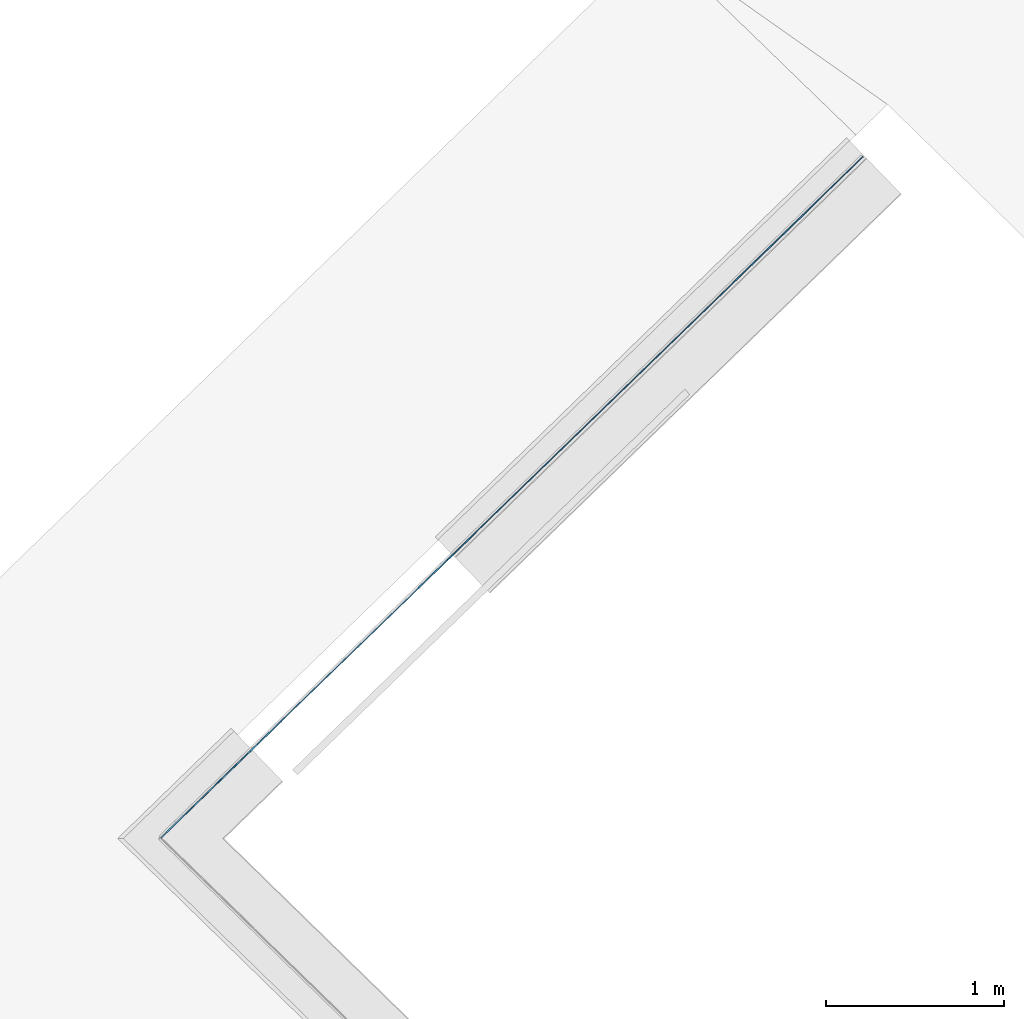
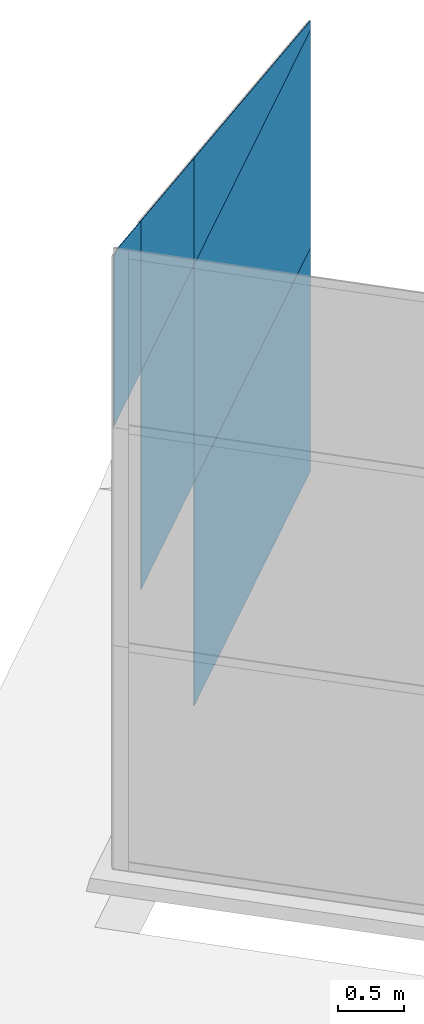
# One storey, part 10 of 13: 6 plates, 1 element without a shape of its own.
"""IFC4 building model written with IfcOpenShell, lengths in metres."""

from ifc_helpers import new_model, entity, si_unit, converted_unit, direction, frame, origin, place, context, subcontext, project, spatial, indexed_curve, outline, extrude, source, transform, mapped, material, type_object, type_shapes, element, aggregate, save


model = new_model("IFC4")

# Units and contexts
model_context = context("Model", 3, precision=1e-05, world=origin(), true_north=direction((6.123233995736766e-17, 1.0)))
body_context = subcontext(model_context, "Body", "Model", "MODEL_VIEW")
ifc_project = project(units=[si_unit("LENGTHUNIT", "METRE"), si_unit("AREAUNIT", "SQUARE_METRE"), si_unit("VOLUMEUNIT", "CUBIC_METRE"), converted_unit("PLANEANGLEUNIT", "DEGREE", entity("IfcPlaneAngleMeasure", 0.017453292519943278), si_unit("PLANEANGLEUNIT", "RADIAN"), dimensions=[0, 0, 0, 0, 0, 0, 0])], contexts=[model_context])

# Site, building, storey
site_placement = place(None, frame((0.0, 0.0, 0.0), z_axis=(0.0, 0.0, 1.0), x_axis=(0.7160934825303189, -0.6980043870045516, 0.0)))
site = spatial("IfcSite", under=ifc_project, at=site_placement, CompositionType="ELEMENT")
building_placement = place(site_placement, origin())
building = spatial("IfcBuilding", under=site, at=building_placement, CompositionType="ELEMENT")
storey_placement = place(building_placement, frame((0.0, 0.0, -7.0)))
storey = spatial("IfcBuildingStorey", under=building, at=storey_placement, Name="-7.00 m", CompositionType="ELEMENT", Elevation=-7.000000000000001)

# Curtain wall, plates
curtain_wall_type = type_object("IfcCurtainWallType", Name="Facciata continua:Vetrata_1", PredefinedType="NOTDEFINED")
curtain_wall_placement = place(storey_placement, frame((0.0, 0.0, 7.0)))
curtain_wall = element("IfcCurtainWall", 1, at=curtain_wall_placement, inside=storey, type_object=curtain_wall_type, Name="Facciata continua:Vetrata_1", ObjectType="Facciata continua:Vetrata_1", PredefinedType="NOTDEFINED")
ifc_material = material(Name="Default - Vetro", Category="Vetro")
plate_type_1 = type_object("IfcPlateType", Name="Pannello sistema:Vetrato_fine", PredefinedType="CURTAIN_PANEL", material=ifc_material)
shared_shape_1 = source(origin(), body_context, "Body", "SweptSolid", [
    extrude(outline(indexed_curve([(-0.0025, -1.624879808806576), (0.0025, -1.624879808806576), (0.0025, 1.624879808806576), (-0.0025, 1.624879808806576), (-0.0025, -1.624879808806576)], self_intersect=False)), frame((0.0, 0.0, 0.0), z_axis=(0.0, 0.0, 1.0), x_axis=(0.0, 1.0, 0.0)), (0.0, 0.0, 1.0), 2.079999999999999),
])
type_shapes(plate_type_1, [shared_shape_1])
plate_1_placement = place(curtain_wall_placement, frame((-27.70563502134957, -3.1169319345284583, -6.9399999999999995), z_axis=(0.0, 0.0, 1.0), x_axis=(-0.027980069795956325, -0.9996084812036228, 0.0)))
plate_1 = element("IfcPlate", 2, at=plate_1_placement, type_object=plate_type_1, material=ifc_material, Name="Pannello sistema:Vetrato_fine", ObjectType="Pannello sistema:Vetrato_fine", PredefinedType="CURTAIN_PANEL", context=body_context, shape_type="MappedRepresentation", body=[
    mapped(shared_shape_1, transform((0.0, 0.0, 0.0), scale=1.0)),
])
plate_type_2 = type_object("IfcPlateType", Name="Pannello sistema:Vetrato_fine", PredefinedType="CURTAIN_PANEL", material=ifc_material)
shared_shape_2 = source(origin(), body_context, "Body", "SweptSolid", [
    extrude(outline(indexed_curve([(-0.0025, -1.624879808806576), (0.0025, -1.624879808806576), (0.0025, 1.6248798088065761), (-0.0025, 1.624879808806576), (-0.0025, -1.624879808806576)], self_intersect=False)), frame((0.0, 0.0, 0.0), z_axis=(0.0, 0.0, 1.0), x_axis=(0.0, 1.0, 0.0)), (0.0, 0.0, 1.0), 2.030000000000001),
])
type_shapes(plate_type_2, [shared_shape_2])
plate_2_placement = place(curtain_wall_placement, frame((-27.70563502134957, -3.1169319345284583, -4.86), z_axis=(0.0, 0.0, 1.0), x_axis=(-0.027980069795956325, -0.9996084812036228, 0.0)))
plate_2 = element("IfcPlate", 3, at=plate_2_placement, type_object=plate_type_2, material=ifc_material, Name="Pannello sistema:Vetrato_fine", ObjectType="Pannello sistema:Vetrato_fine", PredefinedType="CURTAIN_PANEL", context=body_context, shape_type="MappedRepresentation", body=[
    mapped(shared_shape_2, transform((0.0, 0.0, 0.0), scale=1.0)),
])
plate_type_3 = type_object("IfcPlateType", Name="Pannello sistema:Vetrato_fine", PredefinedType="CURTAIN_PANEL", material=ifc_material)
shared_shape_3 = source(origin(), body_context, "Body", "SweptSolid", [
    extrude(outline(indexed_curve([(-0.0025, -0.7402898373861546), (0.0025, -0.7402898373861546), (0.0025, 0.7402898373861544), (-0.0025, 0.7402898373861544), (-0.0025, -0.7402898373861546)], self_intersect=False)), frame((0.0, 0.0, 0.0), z_axis=(0.0, 0.0, 1.0), x_axis=(0.0, 1.0, 0.0)), (0.0, 0.0, 1.0), 2.030000000000001),
])
type_shapes(plate_type_3, [shared_shape_3])
plate_3_placement = place(curtain_wall_placement, frame((-27.77181263312932, -5.481175572348083, -4.86), z_axis=(0.0, 0.0, 1.0), x_axis=(-0.027980069795956325, -0.9996084812036228, 0.0)))
plate_3 = element("IfcPlate", 4, at=plate_3_placement, type_object=plate_type_3, material=ifc_material, Name="Pannello sistema:Vetrato_fine", ObjectType="Pannello sistema:Vetrato_fine", PredefinedType="CURTAIN_PANEL", context=body_context, shape_type="MappedRepresentation", body=[
    mapped(shared_shape_3, transform((0.0, 0.0, 0.0), scale=1.0)),
])
plate_type_4 = type_object("IfcPlateType", Name="Pannello sistema:Vetrato_fine", PredefinedType="CURTAIN_PANEL", material=ifc_material)
shared_shape_4 = source(origin(), body_context, "Body", "SweptSolid", [
    extrude(outline(indexed_curve([(-0.26936551626873934, -1.6248798088065757), (-0.18374935557589755, -1.6248798088065761), (0.7224803881133762, 1.6248798088065761), (-0.26936551626873934, 1.6248798088065761), (-0.26936551626873934, -1.6248798088065757)], self_intersect=False)), frame((0.0, -0.002500000000001176, 0.26936551626873934), z_axis=(0.0, 1.0, 0.0), x_axis=(0.0, 0.0, 1.0)), (0.0, 0.0, 1.0), 0.005),
])
type_shapes(plate_type_4, [shared_shape_4])
plate_4_placement = place(curtain_wall_placement, frame((-27.70563502134957, -3.1169319345284583, -2.829999999999999), z_axis=(0.0, 0.0, 1.0), x_axis=(-0.027980069795956325, -0.9996084812036228, 0.0)))
plate_4 = element("IfcPlate", 5, at=plate_4_placement, type_object=plate_type_4, material=ifc_material, Name="Pannello sistema:Vetrato_fine", ObjectType="Pannello sistema:Vetrato_fine", PredefinedType="CURTAIN_PANEL", context=body_context, shape_type="MappedRepresentation", body=[
    mapped(shared_shape_4, transform((0.0, 0.0, 0.0), scale=1.0)),
])
plate_type_5 = type_object("IfcPlateType", Name="Pannello sistema:Vetrato_fine", PredefinedType="CURTAIN_PANEL", material=ifc_material)
shared_shape_5 = source(origin(), body_context, "Body", "SweptSolid", [
    extrude(outline(indexed_curve([(-0.5991417665849307, -0.7402898373861537), (0.3927041377971849, -0.7402898373861543), (0.8055793953726765, 0.7402898373861537), (-0.5991417665849307, 0.7402898373861543), (-0.5991417665849307, -0.7402898373861537)], self_intersect=False)), frame((0.0, -0.0025000000000034855, 0.5991417665849307), z_axis=(0.0, 1.0, 0.0), x_axis=(0.0, 0.0, 1.0)), (0.0, 0.0, 1.0), 0.005),
])
type_shapes(plate_type_5, [shared_shape_5])
plate_5_placement = place(curtain_wall_placement, frame((-27.77181263312932, -5.481175572348082, -2.829999999999999), z_axis=(0.0, 0.0, 1.0), x_axis=(-0.027980069795956325, -0.9996084812036228, 0.0)))
plate_5 = element("IfcPlate", 6, at=plate_5_placement, type_object=plate_type_5, material=ifc_material, Name="Pannello sistema:Vetrato_fine", ObjectType="Pannello sistema:Vetrato_fine", PredefinedType="CURTAIN_PANEL", context=body_context, shape_type="MappedRepresentation", body=[
    mapped(shared_shape_5, transform((0.0, 0.0, 0.0), scale=1.0)),
])
plate_type_6 = type_object("IfcPlateType", Name="Pannello sistema:Vetrato_fine", PredefinedType="CURTAIN_PANEL", material=ifc_material)
shared_shape_6 = source(origin(), body_context, "Body", "SweptSolid", [
    extrude(outline(indexed_curve([(-0.9169442323915216, -0.43567286017666285), (0.48777692956608565, -0.4356728601766631), (0.6730557676084786, 0.2287410923131899), (0.6730557676084786, 0.32130231402006826), (-0.9169442323915216, 0.32130231402006787), (-0.9169442323915216, -0.43567286017666285)], self_intersect=False)), frame((0.05718527307829568, -0.0024999999999940105, 0.9169442323915216), z_axis=(0.0, 1.0, 0.0), x_axis=(0.0, 0.0, 1.0)), (0.0, 0.0, 1.0), 0.005),
])
type_shapes(plate_type_6, [shared_shape_6])
plate_6_placement = place(curtain_wall_placement, frame((-27.803116103552533, -6.599514974441955, -2.829999999999999), z_axis=(0.0, 0.0, 1.0), x_axis=(-0.027980069795956325, -0.9996084812036228, 0.0)))
plate_6 = element("IfcPlate", 7, at=plate_6_placement, type_object=plate_type_6, material=ifc_material, Name="Pannello sistema:Vetrato_fine", ObjectType="Pannello sistema:Vetrato_fine", PredefinedType="CURTAIN_PANEL", context=body_context, shape_type="MappedRepresentation", body=[
    mapped(shared_shape_6, transform((0.0, 0.0, 0.0), scale=1.0)),
])
aggregate(curtain_wall, [plate_1, plate_2, plate_3, plate_4, plate_5, plate_6])

save(model, "model.ifc")
